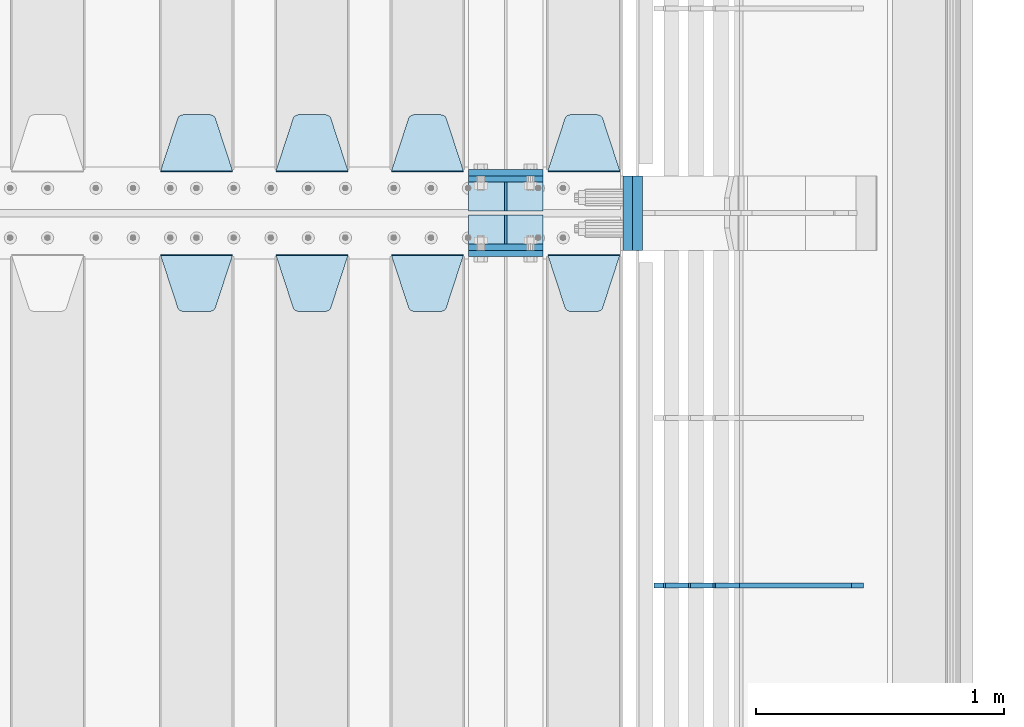
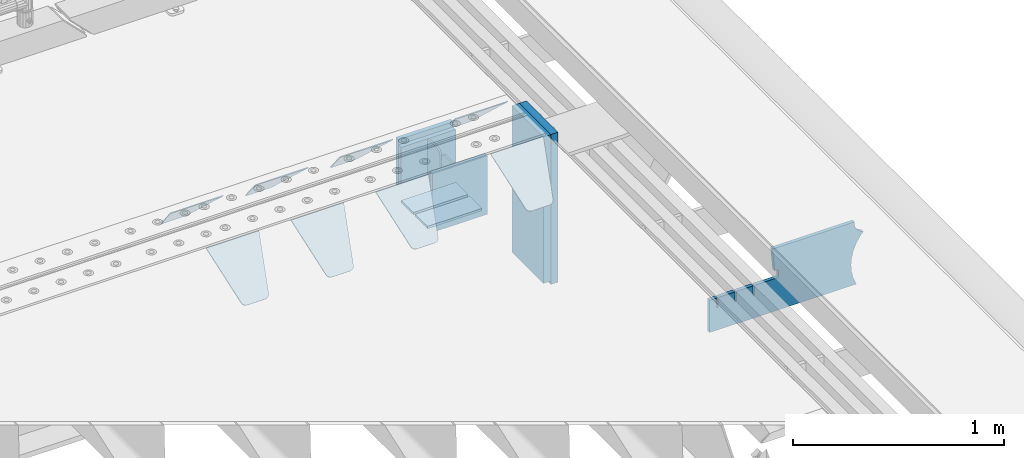
# One storey, part 227 of 247: 19 plates.
"""IFC2X3 building model written with IfcOpenShell, lengths in millimetres."""

from ifc_helpers import new_model, si_unit, frame, origin_with_axes, place, context, subcontext, project, spatial, faceted_brep, material, type_object, element, save


model = new_model("IFC2X3")

# Units and contexts
model_context = context("Model", 3, precision=1e-05, world=origin_with_axes())
body_context = subcontext(model_context, "Body", "Model", "MODEL_VIEW")
ifc_project = project(units=[si_unit("LENGTHUNIT", "METRE", prefix="MILLI"), si_unit("AREAUNIT", "SQUARE_METRE"), si_unit("VOLUMEUNIT", "CUBIC_METRE"), si_unit("MASSUNIT", "GRAM", prefix="KILO"), si_unit("TIMEUNIT", "SECOND"), si_unit("PLANEANGLEUNIT", "RADIAN"), si_unit("SOLIDANGLEUNIT", "STERADIAN"), si_unit("THERMODYNAMICTEMPERATUREUNIT", "DEGREE_CELSIUS"), si_unit("LUMINOUSINTENSITYUNIT", "LUMEN")], contexts=[model_context])

# Site, building, storey
site_placement = place(None, origin_with_axes())
site = spatial("IfcSite", under=ifc_project, at=site_placement, CompositionType="ELEMENT")
building_placement = place(site_placement, origin_with_axes())
building = spatial("IfcBuilding", under=site, at=building_placement, Name="Standard", CompositionType="ELEMENT")
storey_placement = place(building_placement, origin_with_axes())
storey = spatial("IfcBuildingStorey", under=building, at=storey_placement, Name="Undefined", CompositionType="ELEMENT", Elevation=0.0)

# Plates
ifc_material_1 = material(Name="STEEL/S355N")
plate_type_1 = type_object("IfcPlateType", PredefinedType="NOTDEFINED")
for number, where, z_axis, x_axis in (
    (1, (16195.0, 6137.49999999999, -339.999999999993), (0.0, 0.0, 1.0), (1.0, 0.0, 0.0)),
    (2, (16195.0, 5862.49999999999, -339.999999999993), (0.0, 0.0, 1.0), (1.0, 0.0, 0.0)),
):
    element("IfcPlate", number, at=place(storey_placement, frame(where, z_axis=z_axis, x_axis=x_axis)), inside=storey, type_object=plate_type_1, material=ifc_material_1, context=body_context, shape_type="Brep", body=[
        faceted_brep([(0.0, -12.5, 0.0), (0.0, -12.5, 310.0), (0.0, 12.5, 310.0), (0.0, 12.5, 0.0), (300.0, -12.5, 310.0), (300.0, 12.5, 310.0), (300.0, -12.5, 0.0), (300.0, 12.5, 0.0)], [[[0, 1, 2, 3]], [[1, 4, 5, 2]], [[4, 6, 7, 5]], [[6, 0, 3, 7]], [[5, 7, 3, 2]], [[6, 4, 1, 0]]]),
    ])
for number, where, z_axis, x_axis in (
    (3, (16195.0, 5837.5, -340.000000000044), (0.0, 0.0, 1.0), (1.0, 0.0, 0.0)),
    (4, (16195.0, 6162.5, -340.000000000044), (0.0, 0.0, 1.0), (1.0, 0.0, 0.0)),
):
    element("IfcPlate", number, at=place(storey_placement, frame(where, z_axis=z_axis, x_axis=x_axis)), inside=storey, type_object=plate_type_1, material=ifc_material_1, context=body_context, shape_type="Brep", body=[
        faceted_brep([(0.0, -12.5, 0.0), (0.0, -12.5, 340.0), (0.0, 12.5, 340.0), (0.0, 12.5, 0.0), (300.0, -12.5, 340.0), (300.0, 12.5, 340.0), (300.0, -12.5, 0.0), (300.0, 12.5, 0.0)], [[[0, 1, 2, 3]], [[1, 4, 5, 2]], [[4, 6, 7, 5]], [[6, 0, 3, 7]], [[5, 7, 3, 2]], [[6, 4, 1, 0]]]),
    ])
plate_type_2 = type_object("IfcPlateType", PredefinedType="NOTDEFINED")
for number, where, z_axis, x_axis in (
    (5, (16195.0, 5991.99999999999, -342.999999999993), (0.0, -0.999999999999548, -9.5100000000016e-07), (1.0, 0.0, 0.0)),
    (6, (16195.0, 6007.99999999999, -342.999999999993), (0.0, 1.0, 0.0), (1.0, 0.0, 0.0)),
):
    element("IfcPlate", number, at=place(storey_placement, frame(where, z_axis=z_axis, x_axis=x_axis)), inside=storey, type_object=plate_type_2, material=ifc_material_1, context=body_context, shape_type="Brep", body=[
        faceted_brep([(0.0, -7.0, 0.0), (0.0, -7.0, 117.0), (0.0, 7.0, 117.0), (0.0, 7.0, 0.0), (300.0, -7.0, 117.0), (300.0, 7.0, 117.0), (300.0, -7.0, 0.0), (300.0, 7.0, 0.0)], [[[0, 1, 2, 3]], [[1, 4, 5, 2]], [[4, 6, 7, 5]], [[6, 0, 3, 7]], [[5, 7, 3, 2]], [[6, 4, 1, 0]]]),
    ])
plate_type_3 = type_object("IfcPlateType", PredefinedType="NOTDEFINED")
for number, where, z_axis, x_axis in (
    (7, (16345.0, 6007.99999999999, -29.999999999993), (0.0, 0.0, -1.0), (0.0, 1.0, 0.0)),
    (8, (16345.0, 5991.99999999999, -29.999999999993), (0.0, 0.0, -1.0), (0.0, -0.999999999999548, -9.5100000000016e-07)),
):
    element("IfcPlate", number, at=place(storey_placement, frame(where, z_axis=z_axis, x_axis=x_axis)), inside=storey, type_object=plate_type_3, material=ifc_material_1, context=body_context, shape_type="Brep", body=[
        faceted_brep([(0.0, -5.0, 30.0), (0.0, -5.0, 306.0), (0.0, 5.0, 306.0), (0.0, 5.0, 30.0), (117.0, -5.0, 306.0), (117.0, 5.0, 306.0), (117.0, -5.0, 0.0), (117.0, 5.0, 0.0), (30.0, -5.0, 0.0), (30.0, 5.0, 0.0), (24.7905546699922, -5.0, 0.455767409633758), (24.7905546699922, 5.0, 0.455767409633758), (19.73939570023, -5.0, 1.80922137642275), (19.73939570023, 5.0, 1.80922137642275), (15.0, -5.0, 4.01923788646684), (15.0, 5.0, 4.01923788646684), (10.716371709404, -5.0, 7.01866670643066), (10.716371709404, 5.0, 7.01866670643066), (7.01866670643085, -5.0, 10.7163717094038), (7.01866670643085, 5.0, 10.7163717094038), (4.01923788646673, -5.0, 15.0), (4.01923788646673, 5.0, 15.0), (1.80922137642256, -5.0, 19.7393957002299), (1.80922137642256, 5.0, 19.7393957002299), (0.455767409633609, -5.0, 24.7905546699921), (0.455767409633609, 5.0, 24.7905546699921)], [[[0, 1, 2, 3]], [[1, 4, 5, 2]], [[4, 6, 7, 5]], [[6, 8, 9, 7]], [[8, 10, 11, 9]], [[10, 12, 13, 11]], [[12, 14, 15, 13]], [[14, 16, 17, 15]], [[16, 18, 19, 17]], [[18, 20, 21, 19]], [[20, 22, 23, 21]], [[22, 24, 25, 23]], [[24, 0, 3, 25]], [[5, 7, 9, 11, 13, 15, 17, 19, 21, 23, 25, 3, 2]], [[24, 22, 20, 18, 16, 14, 12, 10, 8, 6, 4, 1, 0]]]),
    ])
plate_type_4 = type_object("IfcPlateType", PredefinedType="NOTDEFINED")
plate_1_placement = place(storey_placement, frame((16805.0, 6168.23223304704, -1.76776695296758), z_axis=(0.0, 0.707106781186548, -0.707106781186547), x_axis=(-1.0, 0.0, 0.0)))
element("IfcPlate", 9, at=plate_1_placement, inside=storey, type_object=plate_type_4, material=ifc_material_1, context=body_context, shape_type="Brep", body=[
    faceted_brep([(0.0, -2.49999999999909, 0.0), (69.345504679477, -2.5, 300.17173142483), (69.345504679477, 2.50000000000091, 300.171731424831), (0.0, 2.5, -9.09494701772928e-13), (70.9274061199576, -2.5, 304.897442415399), (70.9274061199576, 2.50000000000091, 304.8974424154), (73.3818627772307, -2.49999999999909, 309.234538108527), (73.3818627772307, 2.5, 309.234538108526), (76.6187032999551, -2.5, 313.023683126102), (76.6187032999551, 2.50000000000091, 313.023683126102), (80.5190132704993, -2.49999999999909, 316.125672595371), (80.5190132704993, 2.50000000000091, 316.125672595372), (84.9395038596849, -2.49999999999909, 318.426546230476), (84.9395038596849, 2.5, 318.426546230475), (89.7177759439219, -2.5, 319.841774983274), (89.7177759439219, 2.50000000000091, 319.841774983275), (94.678286292652, -2.5, 320.319366455077), (94.678286292652, 2.50000000000091, 320.319366455077), (195.321713707348, -2.5, 320.319366455077), (195.321713707348, 2.50000000000091, 320.319366455077), (200.282224056078, -2.5, 319.841774983274), (200.282224056078, 2.50000000000091, 319.841774983275), (205.060496140315, -2.5, 318.426546230475), (205.060496140315, 2.5, 318.426546230474), (209.480986729501, -2.49999999999818, 316.12567259537), (209.480986729501, 2.50000000000091, 316.12567259537), (213.381296700045, -2.5, 313.023683126101), (213.381296700045, 2.50000000000091, 313.023683126101), (216.618137222769, -2.5, 309.234538108525), (216.618137222769, 2.5, 309.234538108525), (219.072593880042, -2.49999999999909, 304.897442415398), (219.072593880042, 2.5, 304.897442415398), (220.654495320523, -2.5, 300.17173142483), (220.654495320523, 2.50000000000091, 300.171731424831), (290.0, -2.49999999999909, 0.0), (290.0, 2.5, -9.09494701772928e-13)], [[[0, 1, 2, 3]], [[1, 4, 5, 2]], [[4, 6, 7, 5]], [[6, 8, 9, 7]], [[8, 10, 11, 9]], [[10, 12, 13, 11]], [[12, 14, 15, 13]], [[14, 16, 17, 15]], [[16, 18, 19, 17]], [[18, 20, 21, 19]], [[20, 22, 23, 21]], [[22, 24, 25, 23]], [[24, 26, 27, 25]], [[26, 28, 29, 27]], [[28, 30, 31, 29]], [[30, 32, 33, 31]], [[32, 34, 35, 33]], [[34, 0, 3, 35]], [[5, 7, 9, 11, 13, 15, 17, 19, 21, 23, 25, 27, 29, 31, 33, 35, 3, 2]], [[34, 32, 30, 28, 26, 24, 22, 20, 18, 16, 14, 12, 10, 8, 6, 4, 1, 0]]]),
])
plate_2_placement = place(storey_placement, frame((16175.0, 6168.23223304704, -1.76776695296758), z_axis=(0.0, 0.707106781186548, -0.707106781186547), x_axis=(-1.0, 0.0, 0.0)))
element("IfcPlate", 10, at=plate_2_placement, inside=storey, type_object=plate_type_4, material=ifc_material_1, context=body_context, shape_type="Brep", body=[
    faceted_brep([(0.0, -2.49999999999909, 0.0), (69.345504679477, -2.5, 300.17173142483), (69.345504679477, 2.50000000000091, 300.171731424831), (0.0, 2.5, -9.09494701772928e-13), (70.9274061199576, -2.5, 304.897442415399), (70.9274061199576, 2.50000000000091, 304.8974424154), (73.3818627772307, -2.49999999999909, 309.234538108527), (73.3818627772307, 2.5, 309.234538108526), (76.6187032999551, -2.5, 313.023683126102), (76.6187032999551, 2.50000000000091, 313.023683126102), (80.5190132704993, -2.49999999999909, 316.125672595371), (80.5190132704993, 2.50000000000091, 316.125672595372), (84.9395038596849, -2.49999999999909, 318.426546230476), (84.9395038596849, 2.5, 318.426546230475), (89.7177759439219, -2.5, 319.841774983274), (89.7177759439219, 2.50000000000091, 319.841774983275), (94.678286292652, -2.5, 320.319366455077), (94.678286292652, 2.50000000000091, 320.319366455077), (195.321713707348, -2.5, 320.319366455077), (195.321713707348, 2.50000000000091, 320.319366455077), (200.282224056078, -2.5, 319.841774983274), (200.282224056078, 2.50000000000091, 319.841774983275), (205.060496140315, -2.5, 318.426546230475), (205.060496140315, 2.5, 318.426546230474), (209.480986729501, -2.49999999999818, 316.12567259537), (209.480986729501, 2.50000000000091, 316.12567259537), (213.381296700045, -2.5, 313.023683126101), (213.381296700045, 2.50000000000091, 313.023683126101), (216.618137222769, -2.5, 309.234538108525), (216.618137222769, 2.5, 309.234538108525), (219.072593880042, -2.49999999999909, 304.897442415398), (219.072593880042, 2.5, 304.897442415398), (220.654495320523, -2.5, 300.17173142483), (220.654495320523, 2.50000000000091, 300.171731424831), (290.0, -2.49999999999909, 0.0), (290.0, 2.5, -9.09494701772928e-13)], [[[0, 1, 2, 3]], [[1, 4, 5, 2]], [[4, 6, 7, 5]], [[6, 8, 9, 7]], [[8, 10, 11, 9]], [[10, 12, 13, 11]], [[12, 14, 15, 13]], [[14, 16, 17, 15]], [[16, 18, 19, 17]], [[18, 20, 21, 19]], [[20, 22, 23, 21]], [[22, 24, 25, 23]], [[24, 26, 27, 25]], [[26, 28, 29, 27]], [[28, 30, 31, 29]], [[30, 32, 33, 31]], [[32, 34, 35, 33]], [[34, 0, 3, 35]], [[5, 7, 9, 11, 13, 15, 17, 19, 21, 23, 25, 27, 29, 31, 33, 35, 3, 2]], [[34, 32, 30, 28, 26, 24, 22, 20, 18, 16, 14, 12, 10, 8, 6, 4, 1, 0]]]),
])
plate_3_placement = place(storey_placement, frame((15710.0, 6168.23223304704, -1.76776695296758), z_axis=(0.0, 0.707106781186548, -0.707106781186547), x_axis=(-1.0, 0.0, 0.0)))
element("IfcPlate", 11, at=plate_3_placement, inside=storey, type_object=plate_type_4, material=ifc_material_1, context=body_context, shape_type="Brep", body=[
    faceted_brep([(0.0, -2.49999999999909, 0.0), (69.345504679477, -2.5, 300.17173142483), (69.345504679477, 2.50000000000091, 300.171731424831), (0.0, 2.5, -9.09494701772928e-13), (70.9274061199576, -2.5, 304.897442415399), (70.9274061199576, 2.50000000000091, 304.8974424154), (73.3818627772307, -2.49999999999909, 309.234538108527), (73.3818627772307, 2.5, 309.234538108526), (76.6187032999551, -2.5, 313.023683126102), (76.6187032999551, 2.50000000000091, 313.023683126102), (80.5190132704993, -2.49999999999909, 316.125672595371), (80.5190132704993, 2.50000000000091, 316.125672595372), (84.9395038596849, -2.49999999999909, 318.426546230476), (84.9395038596849, 2.5, 318.426546230475), (89.7177759439219, -2.5, 319.841774983274), (89.7177759439219, 2.50000000000091, 319.841774983275), (94.678286292652, -2.5, 320.319366455077), (94.678286292652, 2.50000000000091, 320.319366455077), (195.321713707348, -2.5, 320.319366455077), (195.321713707348, 2.50000000000091, 320.319366455077), (200.282224056078, -2.5, 319.841774983274), (200.282224056078, 2.50000000000091, 319.841774983275), (205.060496140315, -2.5, 318.426546230475), (205.060496140315, 2.5, 318.426546230474), (209.480986729501, -2.49999999999818, 316.12567259537), (209.480986729501, 2.50000000000091, 316.12567259537), (213.381296700045, -2.5, 313.023683126101), (213.381296700045, 2.50000000000091, 313.023683126101), (216.618137222769, -2.5, 309.234538108525), (216.618137222769, 2.5, 309.234538108525), (219.072593880042, -2.49999999999909, 304.897442415398), (219.072593880042, 2.5, 304.897442415398), (220.654495320523, -2.5, 300.17173142483), (220.654495320523, 2.50000000000091, 300.171731424831), (290.0, -2.49999999999909, 0.0), (290.0, 2.5, -9.09494701772928e-13)], [[[0, 1, 2, 3]], [[1, 4, 5, 2]], [[4, 6, 7, 5]], [[6, 8, 9, 7]], [[8, 10, 11, 9]], [[10, 12, 13, 11]], [[12, 14, 15, 13]], [[14, 16, 17, 15]], [[16, 18, 19, 17]], [[18, 20, 21, 19]], [[20, 22, 23, 21]], [[22, 24, 25, 23]], [[24, 26, 27, 25]], [[26, 28, 29, 27]], [[28, 30, 31, 29]], [[30, 32, 33, 31]], [[32, 34, 35, 33]], [[34, 0, 3, 35]], [[5, 7, 9, 11, 13, 15, 17, 19, 21, 23, 25, 27, 29, 31, 33, 35, 3, 2]], [[34, 32, 30, 28, 26, 24, 22, 20, 18, 16, 14, 12, 10, 8, 6, 4, 1, 0]]]),
])
plate_4_placement = place(storey_placement, frame((15245.0, 6168.23223304704, -1.76776695296758), z_axis=(0.0, 0.707106781186548, -0.707106781186547), x_axis=(-1.0, 0.0, 0.0)))
element("IfcPlate", 12, at=plate_4_placement, inside=storey, type_object=plate_type_4, material=ifc_material_1, context=body_context, shape_type="Brep", body=[
    faceted_brep([(0.0, -2.49999999999909, 0.0), (69.345504679477, -2.5, 300.17173142483), (69.345504679477, 2.50000000000091, 300.171731424831), (0.0, 2.5, -9.09494701772928e-13), (70.9274061199576, -2.5, 304.897442415399), (70.9274061199576, 2.50000000000091, 304.8974424154), (73.3818627772307, -2.49999999999909, 309.234538108527), (73.3818627772307, 2.5, 309.234538108526), (76.6187032999551, -2.5, 313.023683126102), (76.6187032999551, 2.50000000000091, 313.023683126102), (80.5190132704993, -2.49999999999909, 316.125672595371), (80.5190132704993, 2.50000000000091, 316.125672595372), (84.9395038596849, -2.49999999999909, 318.426546230476), (84.9395038596849, 2.5, 318.426546230475), (89.7177759439219, -2.5, 319.841774983274), (89.7177759439219, 2.50000000000091, 319.841774983275), (94.678286292652, -2.5, 320.319366455077), (94.678286292652, 2.50000000000091, 320.319366455077), (195.321713707348, -2.5, 320.319366455077), (195.321713707348, 2.50000000000091, 320.319366455077), (200.282224056078, -2.5, 319.841774983274), (200.282224056078, 2.50000000000091, 319.841774983275), (205.060496140315, -2.5, 318.426546230475), (205.060496140315, 2.5, 318.426546230474), (209.480986729501, -2.49999999999818, 316.12567259537), (209.480986729501, 2.50000000000091, 316.12567259537), (213.381296700045, -2.5, 313.023683126101), (213.381296700045, 2.50000000000091, 313.023683126101), (216.618137222769, -2.5, 309.234538108525), (216.618137222769, 2.5, 309.234538108525), (219.072593880042, -2.49999999999909, 304.897442415398), (219.072593880042, 2.5, 304.897442415398), (220.654495320523, -2.5, 300.17173142483), (220.654495320523, 2.50000000000091, 300.171731424831), (290.0, -2.49999999999909, 0.0), (290.0, 2.5, -9.09494701772928e-13)], [[[0, 1, 2, 3]], [[1, 4, 5, 2]], [[4, 6, 7, 5]], [[6, 8, 9, 7]], [[8, 10, 11, 9]], [[10, 12, 13, 11]], [[12, 14, 15, 13]], [[14, 16, 17, 15]], [[16, 18, 19, 17]], [[18, 20, 21, 19]], [[20, 22, 23, 21]], [[22, 24, 25, 23]], [[24, 26, 27, 25]], [[26, 28, 29, 27]], [[28, 30, 31, 29]], [[30, 32, 33, 31]], [[32, 34, 35, 33]], [[34, 0, 3, 35]], [[5, 7, 9, 11, 13, 15, 17, 19, 21, 23, 25, 27, 29, 31, 33, 35, 3, 2]], [[34, 32, 30, 28, 26, 24, 22, 20, 18, 16, 14, 12, 10, 8, 6, 4, 1, 0]]]),
])
plate_5_placement = place(storey_placement, frame((16515.0, 5831.76776695594, -1.767766952965), z_axis=(0.0, -0.707106781186548, -0.707106781186547), x_axis=(1.0, 0.0, 0.0)))
element("IfcPlate", 13, at=plate_5_placement, inside=storey, type_object=plate_type_4, material=ifc_material_1, context=body_context, shape_type="Brep", body=[
    faceted_brep([(0.0, -2.49999999999909, 0.0), (69.345504679477, -2.5, 300.17173142483), (69.345504679477, 2.50000000000091, 300.171731424831), (0.0, 2.5, -9.09494701772928e-13), (70.9274061199576, -2.5, 304.897442415399), (70.9274061199576, 2.50000000000091, 304.8974424154), (73.3818627772307, -2.49999999999909, 309.234538108527), (73.3818627772307, 2.5, 309.234538108526), (76.6187032999551, -2.5, 313.023683126102), (76.6187032999551, 2.50000000000091, 313.023683126102), (80.5190132704993, -2.49999999999909, 316.125672595371), (80.5190132704993, 2.50000000000091, 316.125672595372), (84.9395038596849, -2.49999999999909, 318.426546230476), (84.9395038596849, 2.5, 318.426546230475), (89.7177759439219, -2.5, 319.841774983274), (89.7177759439219, 2.50000000000091, 319.841774983275), (94.678286292652, -2.5, 320.319366455077), (94.678286292652, 2.50000000000091, 320.319366455077), (195.321713707348, -2.5, 320.319366455077), (195.321713707348, 2.50000000000091, 320.319366455077), (200.282224056078, -2.5, 319.841774983274), (200.282224056078, 2.50000000000091, 319.841774983275), (205.060496140315, -2.5, 318.426546230475), (205.060496140315, 2.5, 318.426546230474), (209.480986729501, -2.49999999999818, 316.12567259537), (209.480986729501, 2.50000000000091, 316.12567259537), (213.381296700045, -2.5, 313.023683126101), (213.381296700045, 2.50000000000091, 313.023683126101), (216.618137222769, -2.5, 309.234538108525), (216.618137222769, 2.5, 309.234538108525), (219.072593880042, -2.49999999999909, 304.897442415398), (219.072593880042, 2.5, 304.897442415398), (220.654495320523, -2.5, 300.17173142483), (220.654495320523, 2.50000000000091, 300.171731424831), (290.0, -2.49999999999909, 0.0), (290.0, 2.5, -9.09494701772928e-13)], [[[0, 1, 2, 3]], [[1, 4, 5, 2]], [[4, 6, 7, 5]], [[6, 8, 9, 7]], [[8, 10, 11, 9]], [[10, 12, 13, 11]], [[12, 14, 15, 13]], [[14, 16, 17, 15]], [[16, 18, 19, 17]], [[18, 20, 21, 19]], [[20, 22, 23, 21]], [[22, 24, 25, 23]], [[24, 26, 27, 25]], [[26, 28, 29, 27]], [[28, 30, 31, 29]], [[30, 32, 33, 31]], [[32, 34, 35, 33]], [[34, 0, 3, 35]], [[5, 7, 9, 11, 13, 15, 17, 19, 21, 23, 25, 27, 29, 31, 33, 35, 3, 2]], [[34, 32, 30, 28, 26, 24, 22, 20, 18, 16, 14, 12, 10, 8, 6, 4, 1, 0]]]),
])
plate_6_placement = place(storey_placement, frame((15885.0, 5831.76776695594, -1.767766952965), z_axis=(0.0, -0.707106781186548, -0.707106781186547), x_axis=(1.0, 0.0, 0.0)))
element("IfcPlate", 14, at=plate_6_placement, inside=storey, type_object=plate_type_4, material=ifc_material_1, context=body_context, shape_type="Brep", body=[
    faceted_brep([(0.0, -2.49999999999909, 0.0), (69.345504679477, -2.5, 300.17173142483), (69.345504679477, 2.50000000000091, 300.171731424831), (0.0, 2.5, -9.09494701772928e-13), (70.9274061199576, -2.5, 304.897442415399), (70.9274061199576, 2.50000000000091, 304.8974424154), (73.3818627772307, -2.49999999999909, 309.234538108527), (73.3818627772307, 2.5, 309.234538108526), (76.6187032999551, -2.5, 313.023683126102), (76.6187032999551, 2.50000000000091, 313.023683126102), (80.5190132704993, -2.49999999999909, 316.125672595371), (80.5190132704993, 2.50000000000091, 316.125672595372), (84.9395038596849, -2.49999999999909, 318.426546230476), (84.9395038596849, 2.5, 318.426546230475), (89.7177759439219, -2.5, 319.841774983274), (89.7177759439219, 2.50000000000091, 319.841774983275), (94.678286292652, -2.5, 320.319366455077), (94.678286292652, 2.50000000000091, 320.319366455077), (195.321713707348, -2.5, 320.319366455077), (195.321713707348, 2.50000000000091, 320.319366455077), (200.282224056078, -2.5, 319.841774983274), (200.282224056078, 2.50000000000091, 319.841774983275), (205.060496140315, -2.5, 318.426546230475), (205.060496140315, 2.5, 318.426546230474), (209.480986729501, -2.49999999999818, 316.12567259537), (209.480986729501, 2.50000000000091, 316.12567259537), (213.381296700045, -2.5, 313.023683126101), (213.381296700045, 2.50000000000091, 313.023683126101), (216.618137222769, -2.5, 309.234538108525), (216.618137222769, 2.5, 309.234538108525), (219.072593880042, -2.49999999999909, 304.897442415398), (219.072593880042, 2.5, 304.897442415398), (220.654495320523, -2.5, 300.17173142483), (220.654495320523, 2.50000000000091, 300.171731424831), (290.0, -2.49999999999909, 0.0), (290.0, 2.5, -9.09494701772928e-13)], [[[0, 1, 2, 3]], [[1, 4, 5, 2]], [[4, 6, 7, 5]], [[6, 8, 9, 7]], [[8, 10, 11, 9]], [[10, 12, 13, 11]], [[12, 14, 15, 13]], [[14, 16, 17, 15]], [[16, 18, 19, 17]], [[18, 20, 21, 19]], [[20, 22, 23, 21]], [[22, 24, 25, 23]], [[24, 26, 27, 25]], [[26, 28, 29, 27]], [[28, 30, 31, 29]], [[30, 32, 33, 31]], [[32, 34, 35, 33]], [[34, 0, 3, 35]], [[5, 7, 9, 11, 13, 15, 17, 19, 21, 23, 25, 27, 29, 31, 33, 35, 3, 2]], [[34, 32, 30, 28, 26, 24, 22, 20, 18, 16, 14, 12, 10, 8, 6, 4, 1, 0]]]),
])
plate_7_placement = place(storey_placement, frame((15420.0, 5831.76776695594, -1.767766952965), z_axis=(0.0, -0.707106781186548, -0.707106781186547), x_axis=(1.0, 0.0, 0.0)))
element("IfcPlate", 15, at=plate_7_placement, inside=storey, type_object=plate_type_4, material=ifc_material_1, context=body_context, shape_type="Brep", body=[
    faceted_brep([(0.0, -2.49999999999909, 0.0), (69.345504679477, -2.5, 300.17173142483), (69.345504679477, 2.50000000000091, 300.171731424831), (0.0, 2.5, -9.09494701772928e-13), (70.9274061199576, -2.5, 304.897442415399), (70.9274061199576, 2.50000000000091, 304.8974424154), (73.3818627772307, -2.49999999999909, 309.234538108527), (73.3818627772307, 2.5, 309.234538108526), (76.6187032999551, -2.5, 313.023683126102), (76.6187032999551, 2.50000000000091, 313.023683126102), (80.5190132704993, -2.49999999999909, 316.125672595371), (80.5190132704993, 2.50000000000091, 316.125672595372), (84.9395038596849, -2.49999999999909, 318.426546230476), (84.9395038596849, 2.5, 318.426546230475), (89.7177759439219, -2.5, 319.841774983274), (89.7177759439219, 2.50000000000091, 319.841774983275), (94.678286292652, -2.5, 320.319366455077), (94.678286292652, 2.50000000000091, 320.319366455077), (195.321713707348, -2.5, 320.319366455077), (195.321713707348, 2.50000000000091, 320.319366455077), (200.282224056078, -2.5, 319.841774983274), (200.282224056078, 2.50000000000091, 319.841774983275), (205.060496140315, -2.5, 318.426546230475), (205.060496140315, 2.5, 318.426546230474), (209.480986729501, -2.49999999999818, 316.12567259537), (209.480986729501, 2.50000000000091, 316.12567259537), (213.381296700045, -2.5, 313.023683126101), (213.381296700045, 2.50000000000091, 313.023683126101), (216.618137222769, -2.5, 309.234538108525), (216.618137222769, 2.5, 309.234538108525), (219.072593880042, -2.49999999999909, 304.897442415398), (219.072593880042, 2.5, 304.897442415398), (220.654495320523, -2.5, 300.17173142483), (220.654495320523, 2.50000000000091, 300.171731424831), (290.0, -2.49999999999909, 0.0), (290.0, 2.5, -9.09494701772928e-13)], [[[0, 1, 2, 3]], [[1, 4, 5, 2]], [[4, 6, 7, 5]], [[6, 8, 9, 7]], [[8, 10, 11, 9]], [[10, 12, 13, 11]], [[12, 14, 15, 13]], [[14, 16, 17, 15]], [[16, 18, 19, 17]], [[18, 20, 21, 19]], [[20, 22, 23, 21]], [[22, 24, 25, 23]], [[24, 26, 27, 25]], [[26, 28, 29, 27]], [[28, 30, 31, 29]], [[30, 32, 33, 31]], [[32, 34, 35, 33]], [[34, 0, 3, 35]], [[5, 7, 9, 11, 13, 15, 17, 19, 21, 23, 25, 27, 29, 31, 33, 35, 3, 2]], [[34, 32, 30, 28, 26, 24, 22, 20, 18, 16, 14, 12, 10, 8, 6, 4, 1, 0]]]),
])
plate_8_placement = place(storey_placement, frame((14955.0, 5831.76776695594, -1.767766952965), z_axis=(0.0, -0.707106781186548, -0.707106781186547), x_axis=(1.0, 0.0, 0.0)))
element("IfcPlate", 16, at=plate_8_placement, inside=storey, type_object=plate_type_4, material=ifc_material_1, context=body_context, shape_type="Brep", body=[
    faceted_brep([(0.0, -2.49999999999909, 0.0), (69.345504679477, -2.5, 300.17173142483), (69.345504679477, 2.50000000000091, 300.171731424831), (0.0, 2.5, -9.09494701772928e-13), (70.9274061199576, -2.5, 304.897442415399), (70.9274061199576, 2.50000000000091, 304.8974424154), (73.3818627772307, -2.49999999999909, 309.234538108527), (73.3818627772307, 2.5, 309.234538108526), (76.6187032999551, -2.5, 313.023683126102), (76.6187032999551, 2.50000000000091, 313.023683126102), (80.5190132704993, -2.49999999999909, 316.125672595371), (80.5190132704993, 2.50000000000091, 316.125672595372), (84.9395038596849, -2.49999999999909, 318.426546230476), (84.9395038596849, 2.5, 318.426546230475), (89.7177759439219, -2.5, 319.841774983274), (89.7177759439219, 2.50000000000091, 319.841774983275), (94.678286292652, -2.5, 320.319366455077), (94.678286292652, 2.50000000000091, 320.319366455077), (195.321713707348, -2.5, 320.319366455077), (195.321713707348, 2.50000000000091, 320.319366455077), (200.282224056078, -2.5, 319.841774983274), (200.282224056078, 2.50000000000091, 319.841774983275), (205.060496140315, -2.5, 318.426546230475), (205.060496140315, 2.5, 318.426546230474), (209.480986729501, -2.49999999999818, 316.12567259537), (209.480986729501, 2.50000000000091, 316.12567259537), (213.381296700045, -2.5, 313.023683126101), (213.381296700045, 2.50000000000091, 313.023683126101), (216.618137222769, -2.5, 309.234538108525), (216.618137222769, 2.5, 309.234538108525), (219.072593880042, -2.49999999999909, 304.897442415398), (219.072593880042, 2.5, 304.897442415398), (220.654495320523, -2.5, 300.17173142483), (220.654495320523, 2.50000000000091, 300.171731424831), (290.0, -2.49999999999909, 0.0), (290.0, 2.5, -9.09494701772928e-13)], [[[0, 1, 2, 3]], [[1, 4, 5, 2]], [[4, 6, 7, 5]], [[6, 8, 9, 7]], [[8, 10, 11, 9]], [[10, 12, 13, 11]], [[12, 14, 15, 13]], [[14, 16, 17, 15]], [[16, 18, 19, 17]], [[18, 20, 21, 19]], [[20, 22, 23, 21]], [[22, 24, 25, 23]], [[24, 26, 27, 25]], [[26, 28, 29, 27]], [[28, 30, 31, 29]], [[30, 32, 33, 31]], [[32, 34, 35, 33]], [[34, 0, 3, 35]], [[5, 7, 9, 11, 13, 15, 17, 19, 21, 23, 25, 27, 29, 31, 33, 35, 3, 2]], [[34, 32, 30, 28, 26, 24, 22, 20, 18, 16, 14, 12, 10, 8, 6, 4, 1, 0]]]),
])
ifc_material_2 = material()
plate_type_5 = type_object("IfcPlateType", PredefinedType="NOTDEFINED")
plate_9_placement = place(storey_placement, frame((16837.0, 6150.0, -870.0), z_axis=(0.0, 0.0, 1.0), x_axis=(0.0, -0.999999999999548, -9.5100000000016e-07)))
element("IfcPlate", 17, at=plate_9_placement, inside=storey, type_object=plate_type_5, material=ifc_material_2, context=body_context, shape_type="Brep", body=[
    faceted_brep([(0.0, -20.0, 0.0), (0.0, -20.0, 850.0), (0.0, 20.0, 850.0), (0.0, 20.0, 0.0), (300.0, -20.0, 850.0), (300.0, 20.0, 850.0), (300.0, -20.0, -1.81898940354586e-12), (300.0, 20.0, -1.81898940354586e-12)], [[[0, 1, 2, 3]], [[1, 4, 5, 2]], [[4, 6, 7, 5]], [[6, 0, 3, 7]], [[5, 7, 3, 2]], [[6, 4, 1, 0]]]),
])
plate_10_placement = place(storey_placement, frame((16876.9988298906, 6150.0, -889.999999999995), z_axis=(0.0, 0.0, 1.0), x_axis=(0.0, -0.999999999999548, -9.5100000000016e-07)))
element("IfcPlate", 18, at=plate_10_placement, inside=storey, type_object=plate_type_5, material=ifc_material_2, context=body_context, shape_type="Brep", body=[
    faceted_brep([(0.0, -20.0, 0.0), (0.0, -20.0, 870.0), (0.0, 20.0, 870.0), (0.0, 20.0, 0.0), (300.0, -20.0, 870.0), (300.0, 20.0, 870.0), (300.0, -20.0, -1.81898940354586e-12), (300.0, 20.0, -1.81898940354586e-12)], [[[0, 1, 2, 3]], [[1, 4, 5, 2]], [[4, 6, 7, 5]], [[6, 0, 3, 7]], [[5, 7, 3, 2]], [[6, 4, 1, 0]]]),
])
plate_type_6 = type_object("IfcPlateType", PredefinedType="NOTDEFINED")
plate_11_placement = place(storey_placement, frame((17782.9182339676, 4499.99928283691, -374.002067436517), z_axis=(0.0, 0.0, 1.0), x_axis=(-1.0, 0.0, 0.0)))
element("IfcPlate", 19, at=plate_11_placement, inside=storey, type_object=plate_type_6, material=ifc_material_1, context=body_context, shape_type="Brep", body=[
    faceted_brep([(801.919404066546, -10.0, 188.0), (801.919404066546, 10.0, 188.0), (801.919404066546, 10.0, 132.002067436952), (801.919404066546, -10.0, 132.002067436952), (793.919404066546, 10.0, 132.002067436952), (793.919404066546, -10.0, 132.002067436952), (793.919404066546, 10.0, 180.002067436952), (793.919404066546, -10.0, 180.002067436952), (793.527856196906, 10.0, 182.474203391951), (793.527856196906, -10.0, 182.474203391951), (792.391540021545, 10.0, 184.704349455291), (792.391540021545, -10.0, 184.704349455291), (790.621686084887, 10.0, 186.474203391951), (790.621686084887, -10.0, 186.474203391951), (788.391540021545, 10.0, 187.610519567313), (788.391540021545, -10.0, 187.610519567313), (785.919404066546, -10.0, 188.002067436952), (785.919404066546, 10.0, 188.0), (841.0, -10.0, 188.0), (841.0, -10.0, 0.0), (841.0, 10.0, 0.0), (841.0, 10.0, 188.0), (33.3619566736015, -10.0, 0.0), (33.3619566736015, 10.0, 0.0), (36.2350612208174, -10.0, 4.68848050267013), (36.2350612208174, 10.0, 4.68848050267013), (51.4877592159428, -10.0, 41.5117508652784), (51.4877592159428, 10.0, 41.5117508652784), (60.792242588137, -10.0, 80.2677133162964), (60.792242588137, 10.0, 80.2677133162964), (63.9194040769726, -10.0, 120.002067436515), (63.9194040769726, 10.0, 120.002067436515), (60.792242588137, -10.0, 159.736421556734), (60.792242588137, 10.0, 159.736421556734), (51.4877592159428, -10.0, 198.492384007752), (51.4877592159428, 10.0, 198.492384007752), (36.2350612208174, -10.0, 235.31565437036), (36.2350612208174, 10.0, 235.31565437036), (15.4097206482074, -10.0, 269.299521518803), (15.4097206482074, 10.0, 269.299521518803), (-3.35474438098754, -10.0, 291.269887256574), (-3.35474438098754, 10.0, 291.269887256574), (-2.36881039375294, -10.0, 291.426043859339), (-2.36881039375294, 10.0, 291.426043859339), (17.1449676604716, -10.0, 301.368810393754), (17.1449676604716, 10.0, 301.368810393754), (32.6311896062471, -10.0, 316.855032339527), (32.6311896062471, 10.0, 316.855032339527), (42.573956140659, -10.0, 336.368810393754), (42.573956140659, 10.0, 336.368810393754), (46.0, -10.0, 358.0), (46.0, 10.0, 358.0), (45.0495205499137, -10.0, 364.001091067617), (45.0495205499137, 10.0, 364.001091067617), (495.040008544922, -10.0, 364.010009765625), (495.040008544922, 10.0, 364.010009765625), (483.600036621094, -10.0, 233.759994506836), (483.600036621094, 10.0, 233.759994506836), (472.0, -10.0, 233.759994506836), (472.0, 10.0, 233.759994506836), (468.909830056251, -10.0, 233.270559669787), (468.909830056251, 10.0, 233.270559669787), (466.122147477075, -10.0, 231.850164450585), (466.122147477075, 10.0, 231.850164450585), (463.909830056251, -10.0, 229.637847029761), (463.909830056251, 10.0, 229.637847029761), (462.489434837047, -10.0, 226.850164450585), (462.489434837047, 10.0, 226.850164450585), (462.0, -10.0, 223.759994506836), (462.0, 10.0, 223.759994506836), (462.0, -10.0, 198.0), (462.0, 10.0, 198.0), (462.489434837047, -10.0, 194.909830056251), (462.489434837047, 10.0, 194.909830056251), (463.909830056251, -10.0, 192.122147477075), (463.909830056251, 10.0, 192.122147477075), (466.122147477075, -10.0, 189.909830056251), (466.122147477075, 10.0, 189.909830056251), (468.909830056251, -10.0, 188.489434837048), (468.909830056251, 10.0, 188.489434837048), (472.0, -10.0, 188.0), (472.0, 10.0, 188.0), (585.919404066546, -10.0, 188.002067436952), (585.919404066546, 10.0, 188.0), (588.391540021545, -10.0, 187.610519567313), (588.391540021545, 10.0, 187.610519567313), (590.621686084887, -10.0, 186.474203391951), (590.621686084887, 10.0, 186.474203391951), (592.391540021545, -10.0, 184.704349455291), (592.391540021545, 10.0, 184.704349455291), (593.527856196906, -10.0, 182.474203391951), (593.527856196906, 10.0, 182.474203391951), (593.919404066546, -10.0, 180.002067436952), (593.919404066546, 10.0, 180.002067436952), (593.919404066546, -10.0, 132.002067436952), (593.919404066546, 10.0, 132.002067436952), (601.919404066546, -10.0, 132.002067436952), (601.919404066546, 10.0, 132.002067436952), (601.919404066546, -10.0, 188.0), (601.919404066546, 10.0, 188.0), (685.919404066546, -10.0, 188.002067436952), (685.919404066546, 10.0, 188.0), (688.391540021545, -10.0, 187.610519567313), (688.391540021545, 10.0, 187.610519567313), (690.621686084887, -10.0, 186.474203391951), (690.621686084887, 10.0, 186.474203391951), (692.391540021545, -10.0, 184.704349455291), (692.391540021545, 10.0, 184.704349455291), (693.527856196906, -10.0, 182.474203391951), (693.527856196906, 10.0, 182.474203391951), (693.919404066546, -10.0, 180.002067436952), (693.919404066546, 10.0, 180.002067436952), (693.919404066546, -10.0, 132.002067436952), (693.919404066546, 10.0, 132.002067436952), (701.919404066546, -10.0, 132.002067436952), (701.919404066546, 10.0, 132.002067436952), (701.919404066546, -10.0, 188.0), (701.919404066546, 10.0, 188.0)], [[[0, 1, 2, 3]], [[3, 2, 4, 5]], [[5, 4, 6, 7]], [[7, 6, 8, 9]], [[9, 8, 10, 11]], [[11, 10, 12, 13]], [[13, 12, 14, 15]], [[16, 15, 14, 17]], [[18, 19, 20, 21]], [[20, 19, 22, 23]], [[22, 24, 25, 23]], [[26, 27, 25, 24]], [[28, 29, 27, 26]], [[30, 31, 29, 28]], [[32, 33, 31, 30]], [[34, 35, 33, 32]], [[36, 37, 35, 34]], [[38, 39, 37, 36]], [[39, 38, 40, 41]], [[40, 42, 43, 41]], [[44, 45, 43, 42]], [[46, 47, 45, 44]], [[48, 49, 47, 46]], [[50, 51, 49, 48]], [[52, 53, 51, 50]], [[54, 55, 53, 52]], [[54, 56, 57, 55]], [[56, 58, 59, 57]], [[58, 60, 61, 59]], [[60, 62, 63, 61]], [[62, 64, 65, 63]], [[64, 66, 67, 65]], [[66, 68, 69, 67]], [[68, 70, 71, 69]], [[70, 72, 73, 71]], [[72, 74, 75, 73]], [[74, 76, 77, 75]], [[76, 78, 79, 77]], [[78, 80, 81, 79]], [[81, 80, 82, 83]], [[82, 84, 85, 83]], [[86, 87, 85, 84]], [[88, 89, 87, 86]], [[90, 91, 89, 88]], [[92, 93, 91, 90]], [[94, 95, 93, 92]], [[96, 97, 95, 94]], [[98, 99, 97, 96]], [[99, 98, 100, 101]], [[100, 102, 103, 101]], [[104, 105, 103, 102]], [[106, 107, 105, 104]], [[108, 109, 107, 106]], [[110, 111, 109, 108]], [[112, 113, 111, 110]], [[114, 115, 113, 112]], [[116, 117, 115, 114]], [[117, 116, 16, 17]], [[12, 10, 8, 6, 4, 2, 1, 21, 20, 23, 25, 27, 29, 31, 33, 35, 37, 39, 41, 43, 45, 47, 49, 51, 53, 55, 57, 59, 61, 63, 65, 67, 69, 71, 73, 75, 77, 79, 81, 83, 85, 87, 89, 91, 93, 95, 97, 99, 101, 103, 105, 107, 109, 111, 113, 115, 117, 17, 14]], [[18, 21, 1, 0]], [[116, 114, 112, 110, 108, 106, 104, 102, 100, 98, 96, 94, 92, 90, 88, 86, 84, 82, 80, 78, 76, 74, 72, 70, 68, 66, 64, 62, 60, 58, 56, 54, 52, 50, 48, 46, 44, 42, 40, 38, 36, 34, 32, 30, 28, 26, 24, 22, 19, 18, 0, 3, 5, 7, 9, 11, 13, 15, 16]]]),
])

save(model, "model.ifc")
